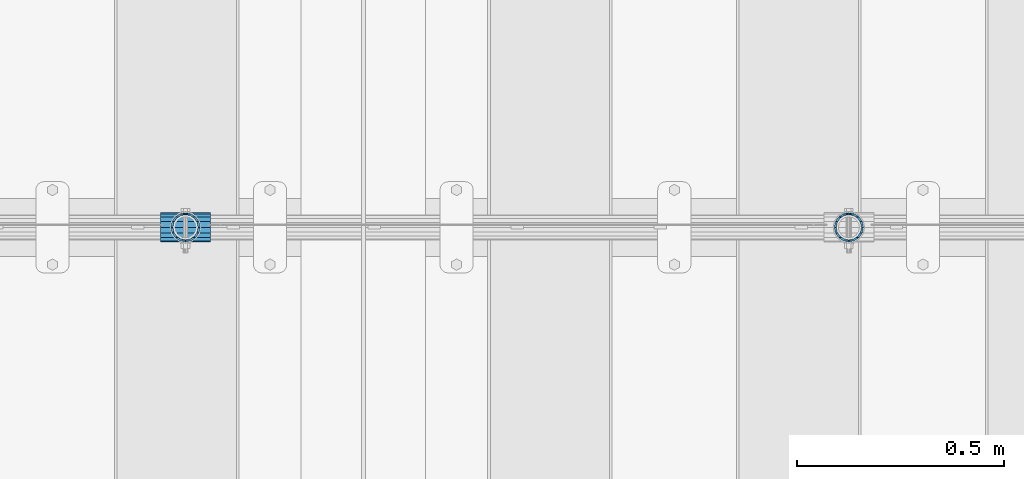
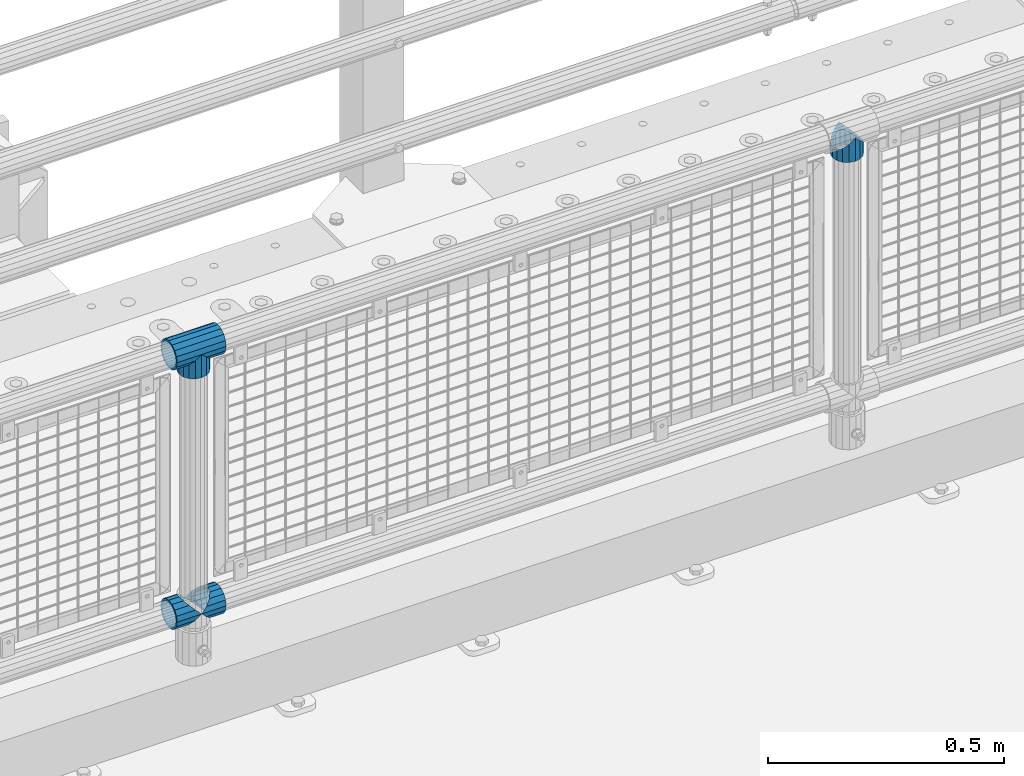
# One storey, part 128 of 208: 5 beams.
"""IFC2X3 building model written with IfcOpenShell, lengths in millimetres."""

from ifc_helpers import new_model, si_unit, frame, origin_with_axes, place, context, subcontext, project, spatial, faceted_brep, material, type_object, element, save


model = new_model("IFC2X3")

# Units and contexts
model_context = context("Model", 3, precision=1e-05, world=origin_with_axes())
body_context = subcontext(model_context, "Body", "Model", "MODEL_VIEW")
ifc_project = project(units=[si_unit("LENGTHUNIT", "METRE", prefix="MILLI"), si_unit("AREAUNIT", "SQUARE_METRE"), si_unit("VOLUMEUNIT", "CUBIC_METRE"), si_unit("MASSUNIT", "GRAM", prefix="KILO"), si_unit("TIMEUNIT", "SECOND"), si_unit("PLANEANGLEUNIT", "RADIAN"), si_unit("SOLIDANGLEUNIT", "STERADIAN"), si_unit("THERMODYNAMICTEMPERATUREUNIT", "DEGREE_CELSIUS"), si_unit("LUMINOUSINTENSITYUNIT", "LUMEN")], contexts=[model_context])

# Site, building, storey
site_placement = place(None, origin_with_axes())
site = spatial("IfcSite", under=ifc_project, at=site_placement, CompositionType="ELEMENT")
building_placement = place(site_placement, origin_with_axes())
building = spatial("IfcBuilding", under=site, at=building_placement, Name="Standard", CompositionType="ELEMENT")
storey_placement = place(building_placement, origin_with_axes())
storey = spatial("IfcBuildingStorey", under=building, at=storey_placement, Name="Undefined", CompositionType="ELEMENT", Elevation=0.0)

# Beams
ifc_material = material(Name="Misc_Undefined")
beam_type = type_object("IfcBeamType", PredefinedType="NOTDEFINED")
beam_1_placement = place(storey_placement, frame((-29029.0, 4664.5, 969.849999999999), z_axis=(0.0, 1.0, 0.0), x_axis=(0.0, 0.0, -1.0)))
element("IfcBeam", 1, at=beam_1_placement, inside=storey, type_object=beam_type, material=ifc_material, context=body_context, shape_type="Brep", body=[
    faceted_brep([(0.0, 0.0, 35.1499999999996), (13.4513226476338, 13.4513226476329, 32.4743655677721), (13.4513226476338, -13.4513226476329, 32.4743655677721), (32.4743655677739, -32.4743655677717, -13.4513226476329), (32.4743655677739, -26.8123795176766, -13.4513226476329), (27.1226768591077, -21.4606908090117, -21.4606908090118), (24.8548033587067, -16.3810424080039, -24.8548033587067), (24.8548033587067, -24.8548033587072, -24.8548033587067), (13.4513226476338, -13.4513226476329, -32.4743655677721), (13.4513226476338, 13.4513226476329, -32.4743655677721), (0.0, 0.0, -35.1499999999996), (20.0882031229849, -11.6144421722805, -28.0397438117179), (16.6306603983685, 0.0, -30.3500000000004), (20.0882031229849, 11.6144421722805, -28.0397438117179), (24.8548033587067, 16.3810424080023, -24.8548033587067), (24.8548033587067, 24.8548033587072, -24.8548033587067), (32.4743655677739, 26.8123795176755, -13.4513226476329), (32.4743655677739, 32.4743655677717, -13.4513226476329), (27.1226768591077, 21.4606908090117, -21.4606908090118), (35.1500000000015, 30.35, 0.0), (35.1500000000015, 35.15, 0.0), (32.8397438117172, 28.0397438117175, -11.6144421722802), (32.8397438117172, 28.0397438117175, 11.6144421722802), (32.4743655677739, 26.812379517676, 13.4513226476329), (32.4743655677739, 32.4743655677717, 13.4513226476329), (27.1226768591005, 21.4606908090117, 21.4606908090118), (24.8548033587067, 16.3810424080032, 24.8548033587067), (24.8548033587067, 24.8548033587072, 24.8548033587067), (20.0882031229921, 11.6144421722805, 28.0397438117179), (16.6306603983685, 0.0, 30.3500000000004), (20.0882031229921, -11.6144421722805, 28.0397438117179), (24.8548033587067, -16.3810424080039, 24.8548033587067), (24.8548033587067, -24.8548033587072, 24.8548033587067), (27.1226768591005, -21.4606908090117, 21.4606908090118), (32.4743655677739, -26.8123795176755, 13.4513226476329), (32.4743655677739, -32.4743655677717, 13.4513226476329), (32.8397438117172, -28.0397438117175, 11.6144421722802), (35.1500000000015, -30.35, 0.0), (35.1500000000015, -35.1499999999996, 0.0), (32.8397438117172, -28.0397438117175, -11.6144421722802), (60.1500000000015, -24.8548033587072, -24.8548033587067), (60.1500000000015, -32.4743655677717, -13.4513226476329), (60.1500000000015, -13.4513226476329, -32.4743655677721), (60.1500000000015, 0.0, -35.1499999999996), (60.1500000000015, 13.4513226476329, -32.4743655677721), (60.1500000000015, 24.8548033587072, -24.8548033587067), (60.1500000000015, 32.4743655677717, -13.4513226476329), (60.1500000000015, 35.15, 0.0), (60.1500000000015, 32.4743655677717, 13.4513226476329), (60.1500000000015, 24.8548033587072, 24.8548033587067), (60.1500000000015, 13.4513226476329, 32.4743655677721), (60.1500000000015, 0.0, 35.1499999999996), (60.1500000000015, -13.4513226476329, 32.4743655677721), (60.1500000000015, -24.8548033587072, 24.8548033587067), (60.1500000000015, -32.4743655677717, 13.4513226476329), (60.1500000000015, -35.15, 0.0), (60.1500000000015, -21.4606908090117, 21.4606908090118), (60.1500000000015, -11.6144421722805, 28.0397438117179), (60.1500000000015, 0.0, 30.3500000000004), (60.1500000000015, 11.6144421722805, 28.0397438117179), (60.1500000000015, 21.4606908090117, 21.4606908090118), (60.1500000000015, 28.0397438117175, 11.6144421722802), (60.1500000000015, 30.35, 0.0), (60.1500000000015, 28.0397438117175, -11.6144421722802), (60.1500000000015, 21.4606908090117, -21.4606908090118), (60.1500000000015, 11.6144421722805, -28.0397438117179), (60.1500000000015, 0.0, -30.3500000000004), (60.1500000000015, -11.6144421722805, -28.0397438117179), (60.1500000000015, -21.4606908090117, -21.4606908090118), (60.1500000000015, -28.0397438117175, -11.6144421722802), (60.1500000000015, -30.35, 0.0), (60.1500000000015, -28.0397438117175, 11.6144421722802)], [[[0, 1, 2]], [[3, 4, 5, 6, 7]], [[8, 9, 10]], [[7, 6, 11, 12, 13, 14, 15, 9, 8]], [[16, 17, 15, 14, 18]], [[19, 20, 17, 16, 21]], [[22, 23, 24, 20, 19]], [[25, 26, 27, 24, 23]], [[2, 1, 27, 26, 28, 29, 30, 31, 32]], [[32, 31, 33, 34, 35]], [[35, 34, 36, 37, 38]], [[38, 37, 39, 4, 3]], [[40, 41, 3, 7]], [[42, 40, 7, 8]], [[43, 42, 8, 10]], [[44, 43, 10, 9]], [[45, 44, 9, 15]], [[46, 45, 15, 17]], [[47, 46, 17, 20]], [[48, 47, 20, 24]], [[49, 48, 24, 27]], [[50, 49, 27, 1]], [[51, 50, 1, 0]], [[52, 51, 0, 2]], [[53, 52, 2, 32]], [[54, 53, 32, 35]], [[55, 54, 35, 38]], [[41, 55, 38, 3]], [[40, 42, 43, 44, 45, 46, 47, 48, 49, 50, 51, 52, 53, 54, 55, 41], [56, 57, 58, 59, 60, 61, 62, 63, 64, 65, 66, 67, 68, 69, 70, 71]], [[71, 70, 37, 36]], [[33, 56, 71, 36, 34]], [[30, 57, 56, 33, 31]], [[58, 57, 30, 29]], [[59, 58, 29, 28]], [[60, 59, 28, 26, 25]], [[61, 60, 25, 23, 22]], [[62, 61, 22, 19]], [[63, 62, 19, 21]], [[18, 64, 63, 21, 16]], [[13, 65, 64, 18, 14]], [[66, 65, 13, 12]], [[67, 66, 12, 11]], [[68, 67, 11, 6, 5]], [[69, 68, 5, 4, 39]], [[70, 69, 39, 37]]]),
])
beam_2_placement = place(storey_placement, frame((-30629.0, 4664.5, 969.849999999999), z_axis=(0.0, 1.0, 0.0), x_axis=(0.0, 0.0, -1.0)))
element("IfcBeam", 2, at=beam_2_placement, inside=storey, type_object=beam_type, material=ifc_material, context=body_context, shape_type="Brep", body=[
    faceted_brep([(0.0, 0.0, 35.1499999999996), (13.4513226476338, 13.4513226476329, 32.4743655677721), (13.4513226476338, -13.4513226476329, 32.4743655677721), (32.4743655677739, -32.4743655677717, -13.4513226476329), (32.4743655677739, -26.8123795176766, -13.4513226476329), (27.1226768591077, -21.4606908090117, -21.4606908090118), (24.8548033587067, -16.3810424080039, -24.8548033587067), (24.8548033587067, -24.8548033587072, -24.8548033587067), (13.4513226476338, -13.4513226476329, -32.4743655677721), (13.4513226476338, 13.4513226476329, -32.4743655677721), (0.0, 0.0, -35.1499999999996), (20.0882031229849, -11.6144421722805, -28.0397438117179), (16.6306603983685, 0.0, -30.3500000000004), (20.0882031229849, 11.6144421722805, -28.0397438117179), (24.8548033587067, 16.3810424080023, -24.8548033587067), (24.8548033587067, 24.8548033587072, -24.8548033587067), (32.4743655677739, 26.8123795176755, -13.4513226476329), (32.4743655677739, 32.4743655677717, -13.4513226476329), (27.1226768591077, 21.4606908090117, -21.4606908090118), (35.1500000000015, 30.35, 0.0), (35.1500000000015, 35.15, 0.0), (32.8397438117172, 28.0397438117175, -11.6144421722802), (32.8397438117172, 28.0397438117175, 11.6144421722802), (32.4743655677739, 26.812379517676, 13.4513226476329), (32.4743655677739, 32.4743655677717, 13.4513226476329), (27.1226768591005, 21.4606908090117, 21.4606908090118), (24.8548033587067, 16.3810424080032, 24.8548033587067), (24.8548033587067, 24.8548033587072, 24.8548033587067), (20.0882031229921, 11.6144421722805, 28.0397438117179), (16.6306603983685, 0.0, 30.3500000000004), (20.0882031229921, -11.6144421722805, 28.0397438117179), (24.8548033587067, -16.3810424080039, 24.8548033587067), (24.8548033587067, -24.8548033587072, 24.8548033587067), (27.1226768591005, -21.4606908090117, 21.4606908090118), (32.4743655677739, -26.8123795176755, 13.4513226476329), (32.4743655677739, -32.4743655677717, 13.4513226476329), (32.8397438117172, -28.0397438117175, 11.6144421722802), (35.1500000000015, -30.35, 0.0), (35.1500000000015, -35.1499999999996, 0.0), (32.8397438117172, -28.0397438117175, -11.6144421722802), (60.1500000000015, -24.8548033587072, -24.8548033587067), (60.1500000000015, -32.4743655677717, -13.4513226476329), (60.1500000000015, -13.4513226476329, -32.4743655677721), (60.1500000000015, 0.0, -35.1499999999996), (60.1500000000015, 13.4513226476329, -32.4743655677721), (60.1500000000015, 24.8548033587072, -24.8548033587067), (60.1500000000015, 32.4743655677717, -13.4513226476329), (60.1500000000015, 35.15, 0.0), (60.1500000000015, 32.4743655677717, 13.4513226476329), (60.1500000000015, 24.8548033587072, 24.8548033587067), (60.1500000000015, 13.4513226476329, 32.4743655677721), (60.1500000000015, 0.0, 35.1499999999996), (60.1500000000015, -13.4513226476329, 32.4743655677721), (60.1500000000015, -24.8548033587072, 24.8548033587067), (60.1500000000015, -32.4743655677717, 13.4513226476329), (60.1500000000015, -35.15, 0.0), (60.1500000000015, -21.4606908090117, 21.4606908090118), (60.1500000000015, -11.6144421722805, 28.0397438117179), (60.1500000000015, 0.0, 30.3500000000004), (60.1500000000015, 11.6144421722805, 28.0397438117179), (60.1500000000015, 21.4606908090117, 21.4606908090118), (60.1500000000015, 28.0397438117175, 11.6144421722802), (60.1500000000015, 30.35, 0.0), (60.1500000000015, 28.0397438117175, -11.6144421722802), (60.1500000000015, 21.4606908090117, -21.4606908090118), (60.1500000000015, 11.6144421722805, -28.0397438117179), (60.1500000000015, 0.0, -30.3500000000004), (60.1500000000015, -11.6144421722805, -28.0397438117179), (60.1500000000015, -21.4606908090117, -21.4606908090118), (60.1500000000015, -28.0397438117175, -11.6144421722802), (60.1500000000015, -30.35, 0.0), (60.1500000000015, -28.0397438117175, 11.6144421722802)], [[[0, 1, 2]], [[3, 4, 5, 6, 7]], [[8, 9, 10]], [[7, 6, 11, 12, 13, 14, 15, 9, 8]], [[16, 17, 15, 14, 18]], [[19, 20, 17, 16, 21]], [[22, 23, 24, 20, 19]], [[25, 26, 27, 24, 23]], [[2, 1, 27, 26, 28, 29, 30, 31, 32]], [[32, 31, 33, 34, 35]], [[35, 34, 36, 37, 38]], [[38, 37, 39, 4, 3]], [[40, 41, 3, 7]], [[42, 40, 7, 8]], [[43, 42, 8, 10]], [[44, 43, 10, 9]], [[45, 44, 9, 15]], [[46, 45, 15, 17]], [[47, 46, 17, 20]], [[48, 47, 20, 24]], [[49, 48, 24, 27]], [[50, 49, 27, 1]], [[51, 50, 1, 0]], [[52, 51, 0, 2]], [[53, 52, 2, 32]], [[54, 53, 32, 35]], [[55, 54, 35, 38]], [[41, 55, 38, 3]], [[40, 42, 43, 44, 45, 46, 47, 48, 49, 50, 51, 52, 53, 54, 55, 41], [56, 57, 58, 59, 60, 61, 62, 63, 64, 65, 66, 67, 68, 69, 70, 71]], [[71, 70, 37, 36]], [[33, 56, 71, 36, 34]], [[30, 57, 56, 33, 31]], [[58, 57, 30, 29]], [[59, 58, 29, 28]], [[60, 59, 28, 26, 25]], [[61, 60, 25, 23, 22]], [[62, 61, 22, 19]], [[63, 62, 19, 21]], [[18, 64, 63, 21, 16]], [[13, 65, 64, 18, 14]], [[66, 65, 13, 12]], [[67, 66, 12, 11]], [[68, 67, 11, 6, 5]], [[69, 68, 5, 4, 39]], [[70, 69, 39, 37]]]),
])
beam_3_placement = place(storey_placement, frame((-30689.15, 4664.5, 969.849999999999), z_axis=(0.0, 0.0, 1.0), x_axis=(1.0, 0.0, 0.0)))
element("IfcBeam", 3, at=beam_3_placement, inside=storey, type_object=beam_type, material=ifc_material, context=body_context, shape_type="Brep", body=[
    faceted_brep([(88.1897438117194, -11.6144421722802, -28.0397438117176), (88.1897438117194, -11.6144421722802, -32.8397438117178), (86.9623795176776, -13.4513226476329, -32.4743655677718), (81.6106908090114, -21.4606908090118, -27.1226768591068), (81.6106908090114, -21.4606908090118, -21.4606908090117), (76.531042407998, -24.8548033587067, -24.8548033587072), (71.7644421722835, -28.0397438117179, -20.0882031229861), (71.7644421722835, -28.0397438117179, -11.6144421722805), (60.1500000000015, -30.3500000000004, -16.6306603983687), (60.1500000000015, -30.35, 0.0), (48.5355578277195, -28.0397438117179, -20.0882031229861), (48.5355578277195, -28.0397438117179, -11.6144421722805), (43.7689575919976, -24.8548033587067, -24.8548033587072), (38.6893091909915, -21.4606908090118, -27.1226768591068), (38.6893091909915, -21.4606908090118, -21.4606908090117), (33.3376204823217, -13.4513226476329, -32.4743655677718), (32.1102561882835, -11.6144421722802, -32.8397438117178), (32.1102561882835, -11.6144421722802, -28.0397438117176), (29.8000000000029, 0.0, -35.15), (29.8000000000029, 0.0, -30.35), (32.1102561882835, 11.6144421722802, -32.8397438117175), (32.1102561882835, 11.6144421722802, -28.0397438117176), (33.3376204823217, 13.4513226476329, -32.4743655677718), (38.6893091909915, 21.4606908090118, -27.122676859108), (38.6893091909915, 21.4606908090118, -21.4606908090117), (43.7689575920012, 24.8548033587067, -24.8548033587072), (48.5355578277195, 28.0397438117179, -20.0882031229838), (48.5355578277195, 28.0397438117179, -11.6144421722805), (60.1500000000015, 30.3500000000004, -16.6306603983671), (60.1500000000015, 30.35, 0.0), (71.7644421722835, 28.0397438117179, -20.0882031229838), (71.7644421722835, 28.0397438117179, -11.6144421722805), (76.5310424080089, 24.8548033587067, -24.8548033587072), (81.6106908090114, 21.4606908090118, -27.122676859108), (81.6106908090114, 21.4606908090118, -21.4606908090117), (86.9623795176776, 13.4513226476329, -32.4743655677718), (88.1897438117194, 11.6144421722802, -32.8397438117175), (88.1897438117194, 11.6144421722802, -28.0397438117176), (90.5, 0.0, -35.15), (90.5, 0.0, -30.35), (0.0, -21.4606908090118, -21.4606908090136), (0.0, -28.0397438117179, -11.6144421722784), (0.0, -11.6144421722802, -28.0397438117143), (0.0, 0.0, -30.3499999999985), (0.0, 11.6144421722802, -28.0397438117143), (0.0, 21.4606908090118, -21.4606908090136), (0.0, 28.0397438117179, -11.6144421722784), (0.0, 30.3500000000004, 0.0), (0.0, 32.4743655677721, -13.4513226476338), (0.0, 35.1499999999996, 0.0), (120.299999999999, 35.1499999999996, 0.0), (120.299999999999, 32.4743655677721, -13.4513226476329), (0.0, 32.4743655677721, 13.4513226476338), (120.299999999999, 32.4743655677721, 13.4513226476329), (0.0, 24.8548033587067, 24.8548033587067), (120.299999999999, 24.8548033587067, 24.8548033587072), (0.0, 13.4513226476329, 32.4743655677739), (120.299999999999, 13.4513226476329, 32.4743655677718), (0.0, 0.0, 35.1499999999996), (120.299999999999, 0.0, 35.15), (0.0, -13.4513226476329, 32.4743655677739), (120.299999999999, -13.4513226476329, 32.4743655677718), (0.0, -24.8548033587067, 24.8548033587067), (120.299999999999, -24.8548033587067, 24.8548033587072), (0.0, -32.4743655677721, 13.4513226476338), (120.299999999999, -32.4743655677721, 13.4513226476329), (0.0, -35.1499999999996, 0.0), (120.299999999999, -35.1499999999996, 0.0), (0.0, -32.4743655677721, -13.4513226476338), (120.299999999999, -32.4743655677721, -13.4513226476329), (0.0, 24.8548033587067, -24.8548033587067), (0.0, 13.4513226476329, -32.4743655677739), (0.0, 0.0, -35.1499999999996), (0.0, -13.4513226476329, -32.4743655677739), (0.0, -24.8548033587067, -24.8548033587067), (0.0, 28.0397438117179, 11.6144421722784), (0.0, 21.4606908090118, 21.4606908090136), (0.0, 11.6144421722802, 28.0397438117143), (0.0, 0.0, 30.3499999999985), (0.0, -11.6144421722802, 28.0397438117143), (0.0, -21.4606908090118, 21.4606908090136), (0.0, -28.0397438117179, 11.6144421722784), (0.0, -30.3500000000004, 0.0), (120.299999999999, -30.3500000000004, 0.0), (120.299999999999, -28.0397438117179, -11.6144421722805), (120.299999999999, -21.4606908090118, -21.4606908090117), (120.299999999999, -11.6144421722802, -28.0397438117176), (120.299999999999, 0.0, -30.35), (120.299999999999, 21.4606908090118, -21.4606908090117), (120.299999999999, 28.0397438117179, -11.6144421722805), (120.299999999999, 11.6144421722802, -28.0397438117176), (120.299999999999, 30.3500000000004, 0.0), (120.299999999999, 28.0397438117179, 11.6144421722805), (120.299999999999, 21.4606908090118, 21.4606908090117), (120.299999999999, 11.6144421722802, 28.0397438117176), (120.299999999999, 0.0, 30.35), (120.299999999999, -11.6144421722802, 28.0397438117176), (120.299999999999, -21.4606908090118, 21.4606908090117), (120.299999999999, -28.0397438117179, 11.6144421722805), (120.299999999999, -24.8548033587067, -24.8548033587072), (120.299999999999, -13.4513226476329, -32.4743655677718), (120.299999999999, 0.0, -35.15), (120.299999999999, 13.4513226476329, -32.4743655677718), (120.299999999999, 24.8548033587067, -24.8548033587072)], [[[0, 1, 2, 3, 4]], [[4, 3, 5, 6, 7]], [[7, 6, 8, 9]], [[9, 8, 10, 11]], [[11, 10, 12, 13, 14]], [[14, 13, 15, 16, 17]], [[17, 16, 18, 19]], [[19, 18, 20, 21]], [[21, 20, 22, 23, 24]], [[24, 23, 25, 26, 27]], [[27, 26, 28, 29]], [[29, 28, 30, 31]], [[31, 30, 32, 33, 34]], [[34, 33, 35, 36, 37]], [[37, 36, 38, 39]], [[39, 38, 1, 0]], [[40, 41, 11, 14]], [[42, 40, 14, 17]], [[43, 42, 17, 19]], [[44, 43, 19, 21]], [[45, 44, 21, 24]], [[46, 45, 24, 27]], [[47, 46, 27, 29]], [[48, 49, 50, 51]], [[49, 52, 53, 50]], [[52, 54, 55, 53]], [[54, 56, 57, 55]], [[56, 58, 59, 57]], [[58, 60, 61, 59]], [[60, 62, 63, 61]], [[62, 64, 65, 63]], [[64, 66, 67, 65]], [[66, 68, 69, 67]], [[64, 62, 60, 58, 56, 54, 52, 49, 48, 70, 71, 72, 73, 74, 68, 66], [41, 40, 42, 43, 44, 45, 46, 47, 75, 76, 77, 78, 79, 80, 81, 82]], [[41, 82, 9, 11]], [[83, 84, 7, 9]], [[84, 85, 4, 7]], [[85, 86, 0, 4]], [[86, 87, 39, 0]], [[88, 89, 31, 34]], [[90, 88, 34, 37]], [[87, 90, 37, 39]], [[89, 91, 29, 31]], [[75, 47, 29, 91, 92]], [[76, 75, 92, 93]], [[77, 76, 93, 94]], [[78, 77, 94, 95]], [[79, 78, 95, 96]], [[80, 79, 96, 97]], [[81, 80, 97, 98]], [[9, 82, 81, 98, 83]], [[99, 100, 101, 102, 103, 51, 50, 53, 55, 57, 59, 61, 63, 65, 67, 69], [97, 96, 95, 94, 93, 92, 91, 89, 88, 90, 87, 86, 85, 84, 83, 98]], [[35, 102, 101, 38, 36]], [[32, 103, 102, 35, 33]], [[28, 26, 25, 70, 48, 51, 103, 32, 30]], [[22, 71, 70, 25, 23]], [[18, 72, 71, 22, 20]], [[73, 72, 18, 16, 15]], [[74, 73, 15, 13, 12]], [[99, 69, 68, 74, 12, 10, 8, 6, 5]], [[100, 99, 5, 3, 2]], [[101, 100, 2, 1, 38]]]),
])
beam_4_placement = place(storey_placement, frame((-30689.15, 4664.5, 298.17), z_axis=(0.0, 1.0, 0.0), x_axis=(1.0, 0.0, 0.0)))
element("IfcBeam", 4, at=beam_4_placement, inside=storey, type_object=beam_type, material=ifc_material, context=body_context, shape_type="Brep", body=[
    faceted_brep([(60.1500000000015, 0.0, -35.1499999999996), (46.6986773523677, 13.4513226476329, -32.4743655677721), (46.6986773523677, -13.4513226476329, -32.4743655677721), (33.0273231408937, 21.4606908090117, 21.4606908090118), (27.6756344322275, 26.812379517676, 13.4513226476329), (27.6756344322275, 32.4743655677717, 13.4513226476329), (35.2951966412948, 24.8548033587072, 24.8548033587067), (35.2951966412948, 16.3810424080032, 24.8548033587067), (27.3102561882915, 28.0397438117175, 11.6144421722802), (25.0, 30.35, 0.0), (25.0, 35.15, 0.0), (27.6756344322275, 26.8123795176755, -13.4513226476329), (27.6756344322275, 32.4743655677717, -13.4513226476329), (27.3102561882843, 28.0397438117175, -11.6144421722802), (35.2951966412948, 16.3810424080024, -24.8548033587067), (35.2951966412948, 24.8548033587072, -24.8548033587067), (33.0273231408864, 21.4606908090117, -21.4606908090118), (40.0617968770239, 11.6144421722805, -28.0397438117179), (43.5193396016402, 0.0, -30.3500000000004), (40.0617968770239, -11.6144421722805, -28.0397438117179), (35.2951966412948, -16.3810424080032, -24.8548033587067), (35.2951966412948, -24.8548033587072, -24.8548033587067), (33.0273231408864, -21.4606908090117, -21.4606908090118), (27.6756344322275, -26.812379517676, -13.4513226476329), (27.6756344322275, -32.4743655677717, -13.4513226476329), (27.3102561882843, -28.0397438117175, -11.6144421722802), (25.0, -30.35, 0.0), (25.0, -35.15, 0.0), (27.3102561882915, -28.0397438117175, 11.6144421722802), (27.6756344322275, -26.8123795176755, 13.4513226476329), (27.6756344322275, -32.4743655677717, 13.4513226476329), (33.0273231408937, -21.4606908090117, 21.4606908090118), (35.2951966412948, -16.3810424080032, 24.8548033587067), (35.2951966412948, -24.8548033587072, 24.8548033587067), (60.1500000000015, 0.0, 35.1499999999996), (46.6986773523677, -13.4513226476329, 32.4743655677721), (46.6986773523677, 13.4513226476329, 32.4743655677721), (40.0617968770093, -11.6144421722805, 28.0397438117179), (43.519339601633, 0.0, 30.3500000000004), (40.0617968770093, 11.6144421722805, 28.0397438117179), (0.0, -32.4743655677721, -13.4513226476338), (0.0, -24.8548033587067, -24.8548033587067), (0.0, -13.4513226476329, -32.4743655677739), (0.0, 0.0, -35.1499999999996), (0.0, 13.4513226476329, -32.4743655677739), (0.0, 24.8548033587067, -24.8548033587067), (0.0, 32.4743655677721, -13.4513226476338), (0.0, 35.1499999999996, 0.0), (0.0, 32.4743655677721, 13.4513226476338), (0.0, 24.8548033587067, 24.8548033587067), (0.0, 13.4513226476329, 32.4743655677739), (0.0, 0.0, 35.1499999999996), (0.0, -32.4743655677721, 13.4513226476338), (0.0, -35.1499999999996, 0.0), (0.0, -24.8548033587067, 24.8548033587067), (0.0, -13.4513226476329, 32.4743655677739), (0.0, -28.0397438117179, -11.6144421722784), (0.0, -21.4606908090118, -21.4606908090136), (0.0, -11.6144421722802, -28.0397438117143), (0.0, 0.0, -30.3499999999985), (0.0, 11.6144421722802, -28.0397438117143), (0.0, 21.4606908090118, -21.4606908090136), (0.0, 28.0397438117179, -11.6144421722784), (0.0, 30.3500000000004, 0.0), (0.0, 28.0397438117179, 11.6144421722784), (0.0, 21.4606908090118, 21.4606908090136), (0.0, 11.6144421722802, 28.0397438117143), (0.0, 0.0, 30.3499999999985), (0.0, -11.6144421722802, 28.0397438117143), (0.0, -21.4606908090118, 21.4606908090136), (0.0, -28.0397438117179, 11.6144421722784), (0.0, -30.3500000000004, 0.0)], [[[0, 1, 2]], [[3, 4, 5, 6, 7]], [[8, 9, 10, 5, 4]], [[11, 12, 10, 9, 13]], [[14, 15, 12, 11, 16]], [[2, 1, 15, 14, 17, 18, 19, 20, 21]], [[21, 20, 22, 23, 24]], [[24, 23, 25, 26, 27]], [[27, 26, 28, 29, 30]], [[30, 29, 31, 32, 33]], [[34, 35, 36]], [[33, 32, 37, 38, 39, 7, 6, 36, 35]], [[40, 41, 21, 24]], [[41, 42, 2, 21]], [[42, 43, 0, 2]], [[43, 44, 1, 0]], [[44, 45, 15, 1]], [[45, 46, 12, 15]], [[46, 47, 10, 12]], [[47, 48, 5, 10]], [[48, 49, 6, 5]], [[49, 50, 36, 6]], [[50, 51, 34, 36]], [[52, 53, 27, 30]], [[54, 52, 30, 33]], [[55, 54, 33, 35]], [[51, 55, 35, 34]], [[53, 40, 24, 27]], [[52, 54, 55, 51, 50, 49, 48, 47, 46, 45, 44, 43, 42, 41, 40, 53], [56, 57, 58, 59, 60, 61, 62, 63, 64, 65, 66, 67, 68, 69, 70, 71]], [[68, 67, 38, 37]], [[31, 69, 68, 37, 32]], [[28, 70, 69, 31, 29]], [[71, 70, 28, 26]], [[56, 71, 26, 25]], [[57, 56, 25, 23, 22]], [[58, 57, 22, 20, 19]], [[59, 58, 19, 18]], [[60, 59, 18, 17]], [[16, 61, 60, 17, 14]], [[13, 62, 61, 16, 11]], [[63, 62, 13, 9]], [[64, 63, 9, 8]], [[65, 64, 8, 4, 3]], [[66, 65, 3, 7, 39]], [[67, 66, 39, 38]]]),
])
beam_5_placement = place(storey_placement, frame((-30629.0, 4664.5, 298.17), z_axis=(0.0, 1.0, 0.0), x_axis=(1.0, 0.0, 0.0)))
element("IfcBeam", 5, at=beam_5_placement, inside=storey, type_object=beam_type, material=ifc_material, context=body_context, shape_type="Brep", body=[
    faceted_brep([(0.0, 0.0, 35.1499999999996), (13.4513226476338, 13.4513226476329, 32.4743655677721), (13.4513226476338, -13.4513226476329, 32.4743655677721), (32.4743655677739, -32.4743655677717, -13.4513226476329), (32.4743655677739, -26.8123795176766, -13.4513226476329), (27.1226768591077, -21.4606908090117, -21.4606908090118), (24.8548033587067, -16.3810424080039, -24.8548033587067), (24.8548033587067, -24.8548033587072, -24.8548033587067), (13.4513226476338, -13.4513226476329, -32.4743655677721), (13.4513226476338, 13.4513226476329, -32.4743655677721), (0.0, 0.0, -35.1499999999996), (20.0882031229849, -11.6144421722805, -28.0397438117179), (16.6306603983685, 0.0, -30.3500000000004), (20.0882031229849, 11.6144421722805, -28.0397438117179), (24.8548033587067, 16.3810424080023, -24.8548033587067), (24.8548033587067, 24.8548033587072, -24.8548033587067), (32.4743655677739, 26.8123795176755, -13.4513226476329), (32.4743655677739, 32.4743655677717, -13.4513226476329), (27.1226768591077, 21.4606908090117, -21.4606908090118), (35.1500000000015, 30.35, 0.0), (35.1500000000015, 35.15, 0.0), (32.8397438117172, 28.0397438117175, -11.6144421722802), (32.8397438117172, 28.0397438117175, 11.6144421722802), (32.4743655677739, 26.812379517676, 13.4513226476329), (32.4743655677739, 32.4743655677717, 13.4513226476329), (27.1226768591005, 21.4606908090117, 21.4606908090118), (24.8548033587067, 16.3810424080032, 24.8548033587067), (24.8548033587067, 24.8548033587072, 24.8548033587067), (20.0882031229921, 11.6144421722805, 28.0397438117179), (16.6306603983685, 0.0, 30.3500000000004), (20.0882031229921, -11.6144421722805, 28.0397438117179), (24.8548033587067, -16.3810424080039, 24.8548033587067), (24.8548033587067, -24.8548033587072, 24.8548033587067), (27.1226768591005, -21.4606908090117, 21.4606908090118), (32.4743655677739, -26.8123795176755, 13.4513226476329), (32.4743655677739, -32.4743655677717, 13.4513226476329), (32.8397438117172, -28.0397438117175, 11.6144421722802), (35.1500000000015, -30.35, 0.0), (35.1500000000015, -35.1499999999996, 0.0), (32.8397438117172, -28.0397438117175, -11.6144421722802), (60.1500000000015, -24.8548033587072, -24.8548033587067), (60.1500000000015, -32.4743655677717, -13.4513226476329), (60.1500000000015, -13.4513226476329, -32.4743655677721), (60.1500000000015, 0.0, -35.1499999999996), (60.1500000000015, 13.4513226476329, -32.4743655677721), (60.1500000000015, 24.8548033587072, -24.8548033587067), (60.1500000000015, 32.4743655677717, -13.4513226476329), (60.1500000000015, 35.15, 0.0), (60.1500000000015, 32.4743655677717, 13.4513226476329), (60.1500000000015, 24.8548033587072, 24.8548033587067), (60.1500000000015, 13.4513226476329, 32.4743655677721), (60.1500000000015, 0.0, 35.1499999999996), (60.1500000000015, -13.4513226476329, 32.4743655677721), (60.1500000000015, -24.8548033587072, 24.8548033587067), (60.1500000000015, -32.4743655677717, 13.4513226476329), (60.1500000000015, -35.15, 0.0), (60.1500000000015, -21.4606908090117, 21.4606908090118), (60.1500000000015, -11.6144421722805, 28.0397438117179), (60.1500000000015, 0.0, 30.3500000000004), (60.1500000000015, 11.6144421722805, 28.0397438117179), (60.1500000000015, 21.4606908090117, 21.4606908090118), (60.1500000000015, 28.0397438117175, 11.6144421722802), (60.1500000000015, 30.35, 0.0), (60.1500000000015, 28.0397438117175, -11.6144421722802), (60.1500000000015, 21.4606908090117, -21.4606908090118), (60.1500000000015, 11.6144421722805, -28.0397438117179), (60.1500000000015, 0.0, -30.3500000000004), (60.1500000000015, -11.6144421722805, -28.0397438117179), (60.1500000000015, -21.4606908090117, -21.4606908090118), (60.1500000000015, -28.0397438117175, -11.6144421722802), (60.1500000000015, -30.35, 0.0), (60.1500000000015, -28.0397438117175, 11.6144421722802)], [[[0, 1, 2]], [[3, 4, 5, 6, 7]], [[8, 9, 10]], [[7, 6, 11, 12, 13, 14, 15, 9, 8]], [[16, 17, 15, 14, 18]], [[19, 20, 17, 16, 21]], [[22, 23, 24, 20, 19]], [[25, 26, 27, 24, 23]], [[2, 1, 27, 26, 28, 29, 30, 31, 32]], [[32, 31, 33, 34, 35]], [[35, 34, 36, 37, 38]], [[38, 37, 39, 4, 3]], [[40, 41, 3, 7]], [[42, 40, 7, 8]], [[43, 42, 8, 10]], [[44, 43, 10, 9]], [[45, 44, 9, 15]], [[46, 45, 15, 17]], [[47, 46, 17, 20]], [[48, 47, 20, 24]], [[49, 48, 24, 27]], [[50, 49, 27, 1]], [[51, 50, 1, 0]], [[52, 51, 0, 2]], [[53, 52, 2, 32]], [[54, 53, 32, 35]], [[55, 54, 35, 38]], [[41, 55, 38, 3]], [[40, 42, 43, 44, 45, 46, 47, 48, 49, 50, 51, 52, 53, 54, 55, 41], [56, 57, 58, 59, 60, 61, 62, 63, 64, 65, 66, 67, 68, 69, 70, 71]], [[71, 70, 37, 36]], [[33, 56, 71, 36, 34]], [[30, 57, 56, 33, 31]], [[58, 57, 30, 29]], [[59, 58, 29, 28]], [[60, 59, 28, 26, 25]], [[61, 60, 25, 23, 22]], [[62, 61, 22, 19]], [[63, 62, 19, 21]], [[18, 64, 63, 21, 16]], [[13, 65, 64, 18, 14]], [[66, 65, 13, 12]], [[67, 66, 12, 11]], [[68, 67, 11, 6, 5]], [[69, 68, 5, 4, 39]], [[70, 69, 39, 37]]]),
])

save(model, "model.ifc")
